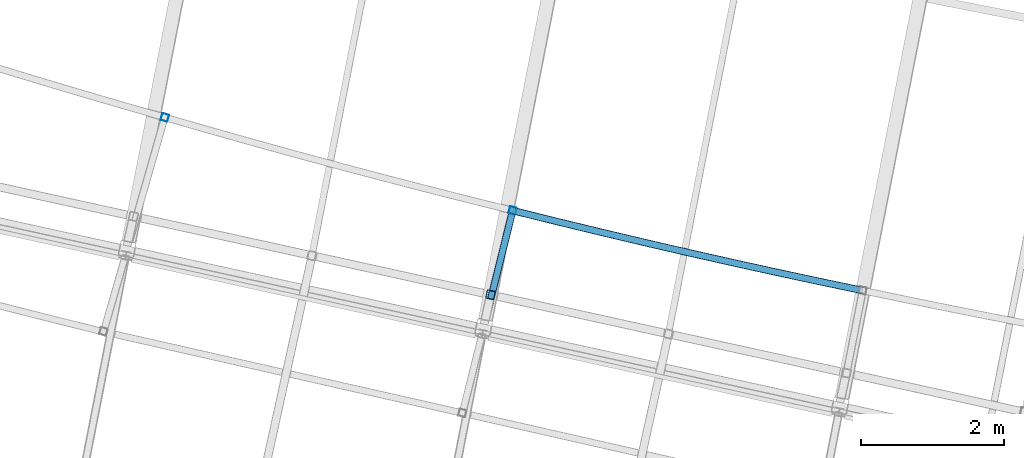
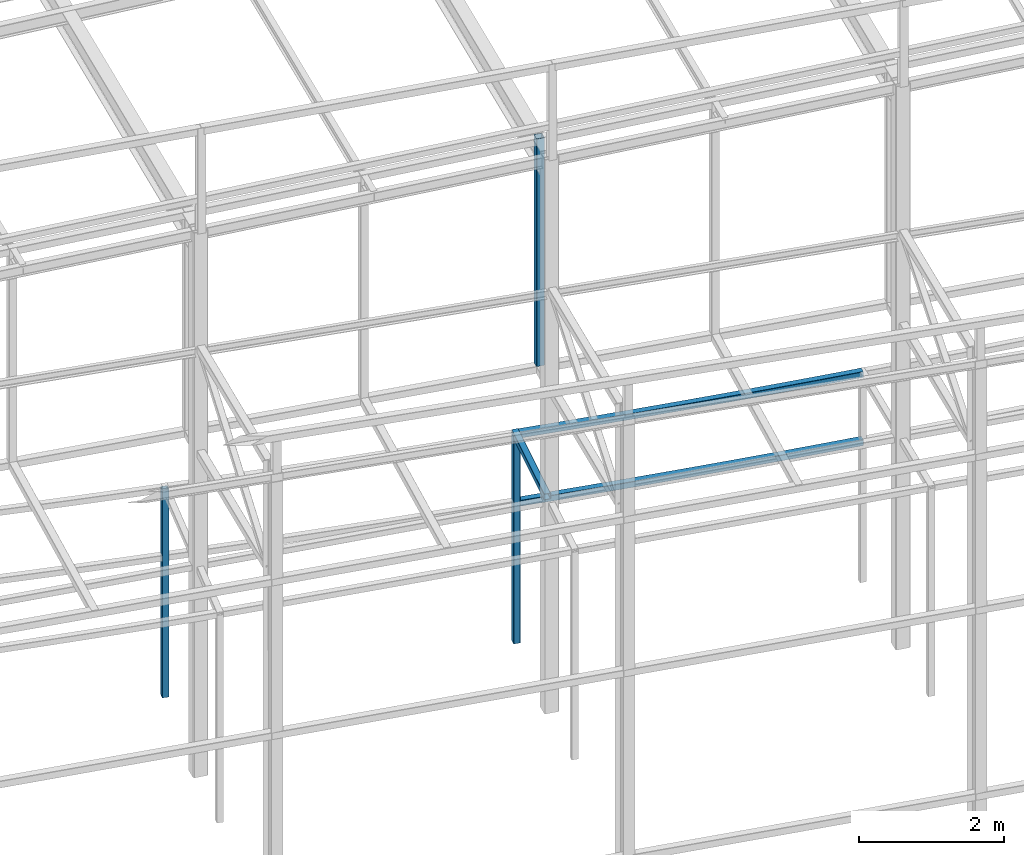
# One storey, part 35 of 215: 6 beams, 6 elements without a shape of their own.
"""IFC2X3 building model written with IfcOpenShell, lengths in millimetres."""

import ifcopenshell
import ifcopenshell.guid

model = None  # the IFC model being written
_history = None  # IfcOwnerHistory: only IFC2X3 demands one
_inside = {}  # id of a spatial element -> (the spatial element, [elements in it])
_under = {}  # id of a project, library or spatial element -> (it, [spatial elements below it])
_declared = {}  # id of a project -> (the project, [libraries it declares])
_typed = {}  # id of a type object -> (the type object, [elements of that type])
_made_of = {}  # id of a material, layer set ... -> (it, [elements and type objects made of it])


def new_model(schema):
    """Start an empty IFC model of exactly this schema.

    Asked for "IFC4X3", IfcOpenShell would pick the latest addendum, in which some entities
    have other attributes; the version numbers below select the first issue.
    IFC2X3 requires an IfcOwnerHistory on every rooted entity: one is made here for all.
    """
    global model, _history
    if schema == "IFC4X3":
        model = ifcopenshell.file(schema_version=(4, 3, 0, 0))
    else:
        model = ifcopenshell.file(schema=schema)
    _inside.clear()
    _under.clear()
    _declared.clear()
    _typed.clear()
    _made_of.clear()
    _history = None
    if model.schema == "IFC2X3":
        org = make("IfcOrganization", Name="unknown")
        user = make(
            "IfcPersonAndOrganization",
            ThePerson=make("IfcPerson", FamilyName="unknown"),
            TheOrganization=org,
        )
        app = make(
            "IfcApplication",
            ApplicationDeveloper=org,
            Version="unknown",
            ApplicationFullName="unknown",
            ApplicationIdentifier="unknown",
        )
        _history = make(
            "IfcOwnerHistory",
            OwningUser=user,
            OwningApplication=app,
            ChangeAction="ADDED",
            CreationDate=0,
        )
    return model


def make(cls, **values):
    """One entity of the class cls with the attributes given. An attribute that is None is left unset."""
    return model.create_entity(
        cls, **{name: value for name, value in values.items() if value is not None}
    )


def entity(cls, *values):
    """Any entity or typed value of the class cls, its attributes in the order of the schema. None: left unset."""
    e = model.create_entity(cls)
    for i, value in enumerate(values):
        if value is not None:
            e[i] = value
    return e


def rooted(cls, **values):
    """An entity with a GlobalId (a new one), such as an element, a storey or a relation."""
    return make(cls, GlobalId=ifcopenshell.guid.new(), OwnerHistory=_history, **values)


def si_unit(unit_type, name, prefix=None):
    """IfcSIUnit, for example si_unit("LENGTHUNIT", "METRE", prefix="MILLI")."""
    return make("IfcSIUnit", UnitType=unit_type, Prefix=prefix, Name=name)


def assignment(units):
    """IfcUnitAssignment: the units of a project."""
    return None if units is None else make("IfcUnitAssignment", Units=units)


def point(xyz):
    """IfcCartesianPoint."""
    return None if xyz is None else make("IfcCartesianPoint", Coordinates=xyz)


def direction(xyz):
    """IfcDirection."""
    return None if xyz is None else make("IfcDirection", DirectionRatios=xyz)


def frame(location, z_axis=None, x_axis=None):
    """IfcAxis2Placement3D, a coordinate frame: its origin and axes. An axis left out is left unset."""
    return make(
        "IfcAxis2Placement3D",
        Location=point(location),
        Axis=direction(z_axis),
        RefDirection=direction(x_axis),
    )


def frame_2d(location, x_axis=None):
    """IfcAxis2Placement2D, a coordinate frame in the plane: its origin and x axis."""
    return make(
        "IfcAxis2Placement2D", Location=point(location), RefDirection=direction(x_axis)
    )


def origin_with_axes():
    """The frame at (0, 0, 0) with the z axis (0, 0, 1) and the x axis (1, 0, 0) written out."""
    return frame((0.0, 0.0, 0.0), z_axis=(0.0, 0.0, 1.0), x_axis=(1.0, 0.0, 0.0))


def origin_2d_with_axis():
    """The frame at (0, 0) in the plane with the x axis (1, 0) written out."""
    return frame_2d((0.0, 0.0), x_axis=(1.0, 0.0))


def place(relative_to, where):
    """IfcLocalPlacement: puts the frame where relative to a parent placement (None: the world)."""
    return make(
        "IfcLocalPlacement", PlacementRelTo=relative_to, RelativePlacement=where
    )


def context(
    kind, dimensions, precision=None, world=None, true_north=None, identifier=None
):
    """IfcGeometricRepresentationContext, for example the 3D "Model" context."""
    return make(
        "IfcGeometricRepresentationContext",
        ContextIdentifier=identifier,
        ContextType=kind,
        CoordinateSpaceDimension=dimensions,
        Precision=precision,
        WorldCoordinateSystem=world,
        TrueNorth=true_north,
    )


def subcontext(parent, identifier, kind, view, scale=None):
    """IfcGeometricRepresentationSubContext, for example "Body" below "Model"."""
    return make(
        "IfcGeometricRepresentationSubContext",
        ContextIdentifier=identifier,
        ContextType=kind,
        ParentContext=parent,
        TargetScale=scale,
        TargetView=view,
    )


def project(units=None, contexts=None):
    """IfcProject with its units and contexts."""
    return rooted(
        "IfcProject",
        Name="project",
        RepresentationContexts=contexts,
        UnitsInContext=assignment(units),
    )


def spatial(cls, under=None, at=None, **own):
    """A site, building, storey or space (cls), placed at a placement, below another one or the project."""
    s = rooted(cls, ObjectPlacement=at, **own)
    if under is not None:
        _under.setdefault(under.id(), (under, []))[1].append(s)
    return s


def profile(cls, at=None, kind="AREA", **sizes):
    """A parametric profile (cls). Its sizes go by their IFC names, for example OverallWidth=200.0."""
    return make(cls, ProfileType=kind, Position=at, **sizes)


def hollow_rectangle(**sizes):
    """IfcRectangleHollowProfileDef."""
    return profile("IfcRectangleHollowProfileDef", **sizes)


def extrude(swept, where, along, depth):
    """IfcExtrudedAreaSolid: the profile swept, set in the frame where, extruded along a direction by depth."""
    return make(
        "IfcExtrudedAreaSolid",
        SweptArea=swept,
        Position=where,
        ExtrudedDirection=direction(along),
        Depth=depth,
    )


def clip(a, b, op="DIFFERENCE"):
    """IfcBooleanClippingResult: the solid a cut by the half space b."""
    return make(
        "IfcBooleanClippingResult", Operator=op, FirstOperand=a, SecondOperand=b
    )


def halfspace(plane, agree):
    """IfcHalfSpaceSolid: all space on one side of the plane z = 0 of the frame plane."""
    return make(
        "IfcHalfSpaceSolid",
        BaseSurface=make("IfcPlane", Position=plane),
        AgreementFlag=agree,
    )


def shape(context_of_items, identifier, shape_type, items):
    """IfcShapeRepresentation: the items that make up one representation, for example the "Body"."""
    return make(
        "IfcShapeRepresentation",
        ContextOfItems=context_of_items,
        RepresentationIdentifier=identifier,
        RepresentationType=shape_type,
        Items=items,
    )


def material(Name=None, Category=None):
    """IfcMaterial."""
    return make("IfcMaterial", Name=Name, Category=Category)


def made_of(thing, what):
    """Note that an element or type object is made of a material, layer set ...; save() writes the relation."""
    if what is not None:
        _made_of.setdefault(what.id(), (what, []))[1].append(thing)
    return thing


def type_object(cls, material=None, **own):
    """A type object (cls), such as IfcWallType, which elements share."""
    return made_of(rooted(cls, **own), material)


def element(
    cls,
    number,
    at=None,
    inside=None,
    cuts=None,
    type_object=None,
    material=None,
    context=None,
    identifier="Body",
    shape_type=None,
    held_by="IfcProductDefinitionShape",
    body=None,
    shapes=None,
    **own,
):
    """One element of the class cls, such as IfcWall. Its Tag is "e" and its number.

    at: its placement. inside: the storey or other place that contains it. cuts: it is an
    opening in that element (IfcRelVoidsElement). A single representation is given by context,
    identifier, shape_type and body (its items); several are given by shapes. held_by: the class
    of the entity that holds the representations. save() writes the other relations.
    """
    e = rooted(cls, Tag="e%d" % number, ObjectPlacement=at, **own)
    if body is not None:
        shapes = [shape(context, identifier, shape_type, body)]
    if shapes is not None:
        e.Representation = make(held_by, Representations=shapes)
    if inside is not None:
        _inside.setdefault(inside.id(), (inside, []))[1].append(e)
    if cuts is not None:
        rooted(
            "IfcRelVoidsElement", RelatingBuildingElement=cuts, RelatedOpeningElement=e
        )
    if type_object is not None:
        _typed.setdefault(type_object.id(), (type_object, []))[1].append(e)
    return made_of(e, material)


def aggregate(whole, parts):
    """IfcRelAggregates: a whole, such as a stair, and the parts it consists of."""
    return rooted("IfcRelAggregates", RelatingObject=whole, RelatedObjects=parts)


def save(model, path):
    """Write the relations noted so far, then the file.

    IfcRelAggregates (storeys below a building ...), IfcRelContainedInSpatialStructure (elements
    in a storey), IfcRelDefinesByType, IfcRelAssociatesMaterial and IfcRelDeclares: one each for
    every whole, place, type object, material and project.
    """
    for whole, parts in _under.values():
        aggregate(whole, parts)
    for where, things in _inside.values():
        rooted(
            "IfcRelContainedInSpatialStructure",
            RelatedElements=things,
            RelatingStructure=where,
        )
    for kind, things in _typed.values():
        rooted("IfcRelDefinesByType", RelatedObjects=things, RelatingType=kind)
    for what, things in _made_of.values():
        rooted("IfcRelAssociatesMaterial", RelatedObjects=things, RelatingMaterial=what)
    for by, libraries in _declared.values():
        rooted("IfcRelDeclares", RelatingContext=by, RelatedDefinitions=libraries)
    model.write(path)


model = new_model("IFC2X3")

# Units and contexts
model_context = context("Model", 3, precision=1e-05, world=origin_with_axes())
body_context = subcontext(model_context, "Body", "Model", "MODEL_VIEW")
ifc_project = project(units=[si_unit("LENGTHUNIT", "METRE", prefix="MILLI"), si_unit("AREAUNIT", "SQUARE_METRE"), si_unit("VOLUMEUNIT", "CUBIC_METRE"), si_unit("MASSUNIT", "GRAM", prefix="KILO"), si_unit("TIMEUNIT", "SECOND"), si_unit("PLANEANGLEUNIT", "RADIAN"), si_unit("SOLIDANGLEUNIT", "STERADIAN"), si_unit("THERMODYNAMICTEMPERATUREUNIT", "DEGREE_CELSIUS"), si_unit("LUMINOUSINTENSITYUNIT", "LUMEN")], contexts=[model_context])

# Site, building, storey
site_placement = place(None, origin_with_axes())
site = spatial("IfcSite", under=ifc_project, at=site_placement, CompositionType="ELEMENT")
building_placement = place(site_placement, origin_with_axes())
building = spatial("IfcBuilding", under=site, at=building_placement, Name="Undefined", CompositionType="ELEMENT")
storey_placement = place(building_placement, origin_with_axes())
storey = spatial("IfcBuildingStorey", under=building, at=storey_placement, Name="Undefined", CompositionType="ELEMENT", Elevation=0.0)

# Assembly, beam
assembly_1_placement = place(storey_placement, origin_with_axes())
assembly_1 = element("IfcElementAssembly", 1, at=assembly_1_placement, inside=storey, Name="Steel Assembly", AssemblyPlace="NOTDEFINED", PredefinedType="RIGID_FRAME")
ifc_material = material(Name="STEEL/S275JR")
beam_type_1 = type_object("IfcBeamType", PredefinedType="NOTDEFINED")
beam_1_placement = place(assembly_1_placement, frame((55392.2632663848, 9638.21914937193, 5610.00000147687), z_axis=(0.222716420982376, 0.974883272922867, 0.0), x_axis=(0.974883272922866, -0.222716420982378, 0.0)))
beam_1 = element("IfcBeam", 2, at=beam_1_placement, type_object=beam_type_1, material=ifc_material, Name="POUTRE", context=body_context, shape_type="SweptSolid", body=[
    entity("IfcRevolvedAreaSolid", entity("IfcRectangleHollowProfileDef", "AREA", None, entity("IfcAxis2Placement2D", entity("IfcCartesianPoint", [0.0, 0.0]), entity("IfcDirection", [1.0, 0.0])), 100.0, 100.0, 4.0, 4.0, 8.0), entity("IfcAxis2Placement3D", entity("IfcCartesianPoint", [5004.88362867552, 9.09494701772928e-13, 0.0]), entity("IfcDirection", [-0.999782538333193, 0.0, -0.020853681786148]), entity("IfcDirection", [-6.93889390390723e-18, -1.0, -3.46944695195361e-18])), entity("IfcAxis1Placement", entity("IfcCartesianPoint", [0.0, 120000.0, 0.0]), entity("IfcDirection", [-1.0, 0.0, 0.0])), 0.0417103870862301),
])
aggregate(assembly_1, [beam_1])

assembly_2_placement = place(storey_placement, origin_with_axes())
assembly_2 = element("IfcElementAssembly", 3, at=assembly_2_placement, inside=storey, Name="Steel Assembly", AssemblyPlace="NOTDEFINED", PredefinedType="RIGID_FRAME")
beam_2_placement = place(assembly_2_placement, frame((55392.2632662939, 9638.21914936402, 6760.00000147687), z_axis=(0.222716420982376, 0.974883272922867, 0.0), x_axis=(0.974883272922866, -0.222716420982378, 0.0)))
beam_2 = element("IfcBeam", 4, at=beam_2_placement, type_object=beam_type_1, material=ifc_material, Name="POUTRE", context=body_context, shape_type="SweptSolid", body=[
    entity("IfcRevolvedAreaSolid", entity("IfcRectangleHollowProfileDef", "AREA", None, entity("IfcAxis2Placement2D", entity("IfcCartesianPoint", [0.0, 0.0]), entity("IfcDirection", [1.0, 0.0])), 100.0, 100.0, 4.0, 4.0, 8.0), entity("IfcAxis2Placement3D", entity("IfcCartesianPoint", [5004.88362867552, 9.09494701772928e-13, 0.0]), entity("IfcDirection", [-0.999782538333193, 0.0, -0.020853681786148]), entity("IfcDirection", [-6.93889390390723e-18, -1.0, -3.46944695195361e-18])), entity("IfcAxis1Placement", entity("IfcCartesianPoint", [0.0, 120000.0, 0.0]), entity("IfcDirection", [-1.0, 0.0, 0.0])), 0.0417103870853994),
])
aggregate(assembly_2, [beam_2])

assembly_3_placement = place(storey_placement, origin_with_axes())
assembly_3 = element("IfcElementAssembly", 5, at=assembly_3_placement, inside=storey, Name="Steel Assembly", AssemblyPlace="NOTDEFINED", PredefinedType="RIGID_FRAME")
beam_3_placement = place(assembly_3_placement, frame((50543.4160313176, 10936.7000339951, 6760.00000147687), z_axis=(-0.961377854576722, 0.27523193987882, 0.0), x_axis=(0.0, 0.0, -1.0)))
beam_3 = element("IfcBeam", 6, at=beam_3_placement, type_object=beam_type_1, material=ifc_material, Name="MONTANT", context=body_context, shape_type="SweptSolid", body=[
    extrude(hollow_rectangle(XDim=100.0, YDim=100.0, WallThickness=4.0, InnerFilletRadius=4.0, OuterFilletRadius=8.0, at=origin_2d_with_axis()), frame((3499.99999998675, 0.0, 0.0), z_axis=(-1.0, 0.0, 0.0), x_axis=(-6.93889390390723e-18, -1.0, -3.46944695195361e-18)), (0.0, 0.0, 1.0), 3500.0),
])
aggregate(assembly_3, [beam_3])

assembly_4_placement = place(storey_placement, origin_with_axes())
assembly_4 = element("IfcElementAssembly", 7, at=assembly_4_placement, inside=storey, Name="Steel Assembly", AssemblyPlace="NOTDEFINED", PredefinedType="RIGID_FRAME")
beam_4_placement = place(assembly_4_placement, frame((55392.2632662939, 9638.21914936402, 6760.00000147687), z_axis=(-0.970514446045369, 0.241042963011268, 0.0), x_axis=(0.0, 0.0, -1.0)))
beam_4 = element("IfcBeam", 8, at=beam_4_placement, type_object=beam_type_1, material=ifc_material, Name="MONTANT", context=body_context, shape_type="SweptSolid", body=[
    extrude(hollow_rectangle(XDim=100.0, YDim=100.0, WallThickness=4.0, InnerFilletRadius=4.0, OuterFilletRadius=8.0, at=origin_2d_with_axis()), frame((3499.99999998675, 0.0, 0.0), z_axis=(-1.0, 0.0, 0.0), x_axis=(-6.93889390390723e-18, -1.0, -3.46944695195361e-18)), (0.0, 0.0, 1.0), 3500.0),
])
aggregate(assembly_4, [beam_4])

assembly_5_placement = place(storey_placement, origin_with_axes())
assembly_5 = element("IfcElementAssembly", 9, at=assembly_5_placement, inside=storey, Name="Steel Assembly", AssemblyPlace="NOTDEFINED", PredefinedType="RIGID_FRAME")
beam_5_placement = place(assembly_5_placement, frame((55035.7680995331, 8202.85946235228, 6760.00000147687), z_axis=(-0.970514446045369, 0.241042963011268, 0.0), x_axis=(0.241043332093801, 0.970514354377676, 0.0)))
beam_5 = element("IfcBeam", 10, at=beam_5_placement, type_object=beam_type_1, material=ifc_material, Name="POUTRE", context=body_context, shape_type="Clipping", body=[
    clip(extrude(hollow_rectangle(XDim=100.0, YDim=100.0, WallThickness=4.0, InnerFilletRadius=4.0, OuterFilletRadius=8.0, at=origin_2d_with_axis()), frame((1528.96796279802, 0.0, 0.0), z_axis=(-1.0, 0.0, 0.0), x_axis=(-6.93889390390723e-18, -1.0, -3.46944695195361e-18)), (0.0, 0.0, 1.0), 1663.8), halfspace(frame((-86.3700621278767, -50.0, -69.2124401021938), z_axis=(0.99873098743724, 0.0, 0.0503628308640023), x_axis=(-6.93889390390723e-18, -1.0, -3.46944695195361e-18)), True)),
])
aggregate(assembly_5, [beam_5])

assembly_6_placement = place(storey_placement, origin_with_axes())
assembly_6 = element("IfcElementAssembly", 11, at=assembly_6_placement, inside=storey, Name="Steel Assembly", AssemblyPlace="NOTDEFINED", PredefinedType="RIGID_FRAME")
beam_type_2 = type_object("IfcBeamType", PredefinedType="NOTDEFINED")
beam_6_placement = place(assembly_6_placement, frame((55084.6991904489, 8462.87253129042, 12602.3393206296), z_axis=(-0.214538758981639, -0.97671547591641, 0.0), x_axis=(0.0, 0.0, -1.0)))
beam_6 = element("IfcBeam", 12, at=beam_6_placement, type_object=beam_type_2, material=ifc_material, Name="LISSE", context=body_context, shape_type="SweptSolid", body=[
    extrude(hollow_rectangle(XDim=120.0, YDim=120.0, WallThickness=5.0, InnerFilletRadius=5.0, OuterFilletRadius=10.0, at=origin_2d_with_axis()), frame((3836.33851187823, 7.27595763957019e-12, 3.63797880848005e-12), z_axis=(-1.0, 0.0, 0.0), x_axis=(-6.93889390390723e-18, -1.0, -3.46944695195361e-18)), (0.0, 0.0, 1.0), 3836.3),
])
aggregate(assembly_6, [beam_6])

save(model, "model.ifc")
